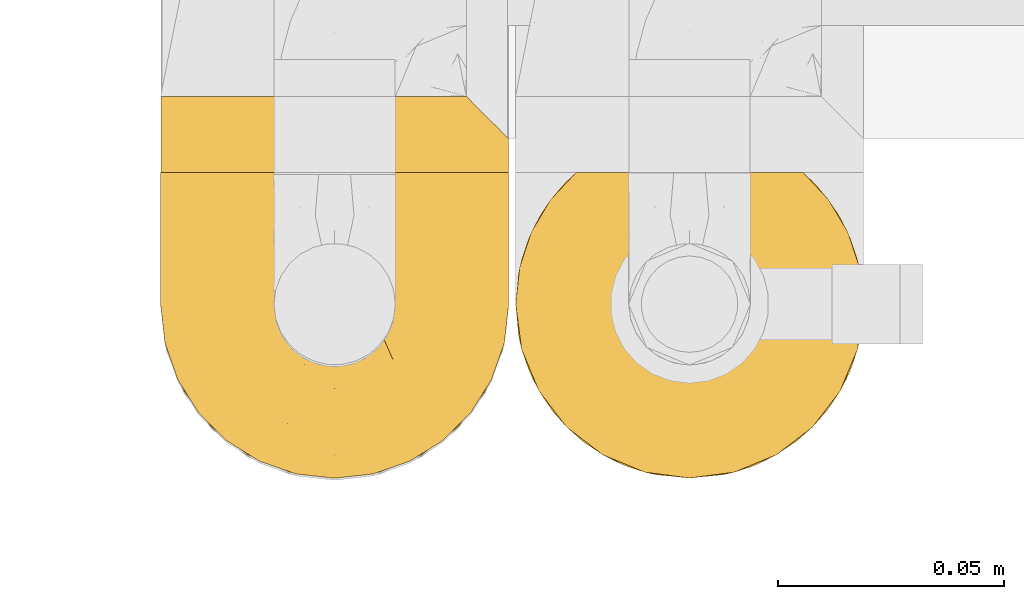
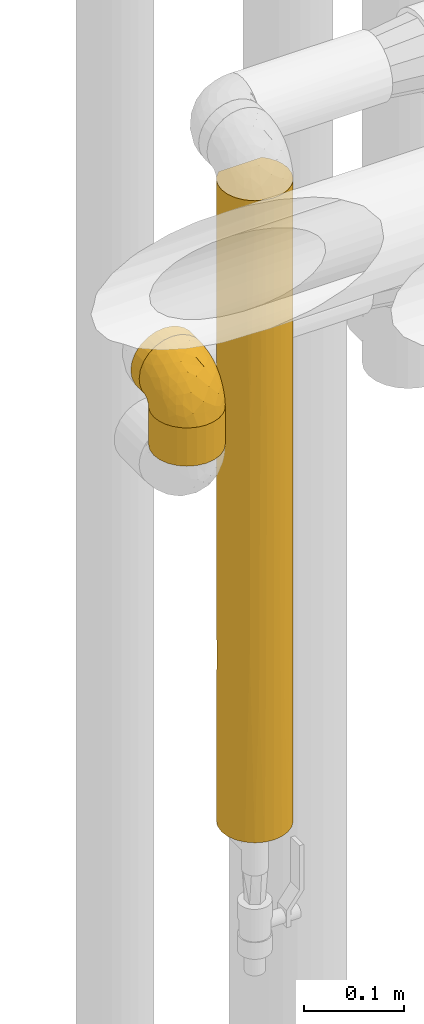
# One storey, part 465 of 827: 4 coverings.
"""IFC2X3 building model written with IfcOpenShell, lengths in millimetres."""

from ifc_helpers import new_model, entity, si_unit, converted_unit, derived_unit, direction, frame, origin, place, context, subcontext, project, spatial, faceted_brep, element, save


model = new_model("IFC2X3")

# Units and contexts
model_context = context("Model", 3, precision=0.01, world=origin(), true_north=direction((6.12303176911189e-17, 1.0)))
body_context = subcontext(model_context, "Body", "Model", "MODEL_VIEW")
ifc_project = project(units=[si_unit("LENGTHUNIT", "METRE", prefix="MILLI"), si_unit("AREAUNIT", "SQUARE_METRE"), si_unit("VOLUMEUNIT", "CUBIC_METRE"), converted_unit("PLANEANGLEUNIT", "DEGREE", entity("IfcRatioMeasure", 0.0174532925199433), si_unit("PLANEANGLEUNIT", "RADIAN"), dimensions=[0, 0, 0, 0, 0, 0, 0]), si_unit("MASSUNIT", "GRAM", prefix="KILO"), derived_unit("MASSDENSITYUNIT", [(si_unit("MASSUNIT", "GRAM", prefix="KILO"), 1), (si_unit("LENGTHUNIT", "METRE"), -3)]), derived_unit("MOMENTOFINERTIAUNIT", [(si_unit("LENGTHUNIT", "METRE"), 4)]), si_unit("TIMEUNIT", "SECOND"), si_unit("FREQUENCYUNIT", "HERTZ"), si_unit("THERMODYNAMICTEMPERATUREUNIT", "DEGREE_CELSIUS"), derived_unit("THERMALTRANSMITTANCEUNIT", [(si_unit("MASSUNIT", "GRAM", prefix="KILO"), 1), (si_unit("THERMODYNAMICTEMPERATUREUNIT", "KELVIN"), -1), (si_unit("TIMEUNIT", "SECOND"), -3)]), derived_unit("VOLUMETRICFLOWRATEUNIT", [(si_unit("LENGTHUNIT", "METRE"), 3), (si_unit("TIMEUNIT", "SECOND"), -1)]), derived_unit("MASSFLOWRATEUNIT", [(si_unit("MASSUNIT", "GRAM", prefix="KILO"), 1), (si_unit("TIMEUNIT", "SECOND"), -1)]), derived_unit("ROTATIONALFREQUENCYUNIT", [(si_unit("TIMEUNIT", "SECOND"), -1)]), si_unit("ELECTRICCURRENTUNIT", "AMPERE"), si_unit("ELECTRICVOLTAGEUNIT", "VOLT"), si_unit("POWERUNIT", "WATT"), si_unit("FORCEUNIT", "NEWTON", prefix="KILO"), si_unit("ILLUMINANCEUNIT", "LUX"), si_unit("LUMINOUSFLUXUNIT", "LUMEN"), si_unit("LUMINOUSINTENSITYUNIT", "CANDELA"), derived_unit("USERDEFINED", [(si_unit("MASSUNIT", "GRAM", prefix="KILO"), -1), (si_unit("LENGTHUNIT", "METRE"), -2), (si_unit("TIMEUNIT", "SECOND"), 3), (si_unit("LUMINOUSFLUXUNIT", "LUMEN"), 1)]), derived_unit("LINEARVELOCITYUNIT", [(si_unit("LENGTHUNIT", "METRE"), 1), (si_unit("TIMEUNIT", "SECOND"), -1)]), si_unit("PRESSUREUNIT", "PASCAL"), derived_unit("USERDEFINED", [(si_unit("LENGTHUNIT", "METRE"), -2), (si_unit("MASSUNIT", "GRAM", prefix="KILO"), 1), (si_unit("TIMEUNIT", "SECOND"), -2)]), derived_unit("LINEARFORCEUNIT", [(si_unit("MASSUNIT", "GRAM", prefix="KILO"), 1), (si_unit("LENGTHUNIT", "METRE"), 1), (si_unit("TIMEUNIT", "SECOND"), -2), (si_unit("LENGTHUNIT", "METRE"), -1)]), derived_unit("PLANARFORCEUNIT", [(si_unit("MASSUNIT", "GRAM", prefix="KILO"), 1), (si_unit("LENGTHUNIT", "METRE"), 1), (si_unit("TIMEUNIT", "SECOND"), -2), (si_unit("LENGTHUNIT", "METRE"), -2)])], contexts=[model_context])

# Site, building, storey
site_placement = place(None, origin())
site = spatial("IfcSite", under=ifc_project, at=site_placement, CompositionType="ELEMENT")
building_placement = place(site_placement, origin())
building = spatial("IfcBuilding", under=site, at=building_placement, CompositionType="ELEMENT")
storey_placement = place(building_placement, frame((0.0, 0.0, 28200.0)))
storey = spatial("IfcBuildingStorey", under=building, at=storey_placement, Name="08", CompositionType="ELEMENT", Elevation=28200.0)

# Coverings
covering_1_placement = place(storey_placement, frame((58529.6, 16264.84, 1836.7)))
element("IfcCovering", 1, at=covering_1_placement, inside=storey, Name=":ADSK_", ObjectType=":ADSK_", PredefinedType="INSULATION", context=body_context, shape_type="Brep", body=[
    faceted_brep([(73.25, 20.8, 784.2), (77.09, 30.06, 784.2), (78.4, 40.0, 784.2), (77.51, 48.2, 784.2), (74.9, 56.01, 784.2), (70.68, 63.08, 784.2), (65.05, 69.1, 784.2), (14.94, 69.1, 784.2), (9.31, 63.08, 784.2), (5.09, 56.01, 784.2), (2.48, 48.2, 784.2), (1.6, 40.0, 784.2), (2.9, 30.06, 784.2), (6.74, 20.8, 784.2), (12.84, 12.84, 784.2), (20.8, 6.74, 784.2), (30.06, 2.9, 784.2), (40.0, 1.6, 784.2), (49.93, 2.9, 784.2), (59.2, 6.74, 784.2), (67.15, 12.84, 784.2), (73.25, 20.8, 0.0), (67.15, 12.84, 0.0), (59.2, 6.74, 0.0), (49.93, 2.9, 0.0), (40.0, 1.6, 0.0), (30.06, 2.9, 0.0), (20.8, 6.74, 0.0), (12.84, 12.84, 0.0), (6.74, 20.8, 0.0), (2.9, 30.06, 0.0), (1.6, 40.0, 0.0), (2.9, 49.93, 0.0), (6.74, 59.2, 0.0), (12.84, 67.15, 0.0), (20.8, 73.25, 0.0), (30.06, 77.09, 0.0), (40.0, 78.4, 0.0), (49.93, 77.09, 0.0), (59.2, 73.25, 0.0), (67.15, 67.15, 0.0), (73.25, 59.2, 0.0), (77.09, 49.93, 0.0), (78.4, 40.0, 0.0), (77.09, 30.06, 0.0), (63.37, 9.53, 276.32), (55.3, 4.78, 607.88), (48.47, 2.54, 545.32), (53.31, 3.98, 185.06), (54.69, 4.52, 392.1), (47.49, 2.33, 304.24), (40.0, 1.6, 216.37), (70.46, 16.62, 233.29), (40.0, 1.6, 392.1), (40.0, 1.6, 567.83), (63.37, 9.53, 550.92), (75.47, 25.3, 392.1), (77.66, 32.5, 479.96), (76.01, 26.68, 599.14), (77.45, 31.52, 238.88), (75.21, 24.69, 176.32), (70.46, 16.62, 507.88), (78.4, 40.0, 392.1), (78.4, 40.0, 567.83), (78.4, 40.0, 216.37), (78.4, 40.0, 351.45), (68.42, 65.82, 310.48), (75.47, 54.69, 206.37), (77.08, 49.96, 459.64), (72.98, 59.66, 400.96), (62.59, 71.04, 388.61), (68.03, 66.24, 548.91), (77.79, 46.8, 218.92), (62.47, 71.13, 597.69), (64.09, 69.9, 180.01), (54.48, 75.56, 231.84), (40.0, 78.4, 558.53), (46.78, 77.79, 775.5), (50.2, 77.01, 468.31), (53.36, 76.0, 777.3), (40.0, 78.4, 342.15), (46.73, 77.8, 213.7), (59.51, 73.07, 780.23), (40.0, 78.4, 774.9), (57.05, 74.4, 489.42), (25.51, 75.56, 231.84), (22.94, 74.4, 489.42), (29.79, 77.01, 468.31), (17.52, 71.13, 597.69), (20.48, 73.07, 780.23), (33.26, 77.8, 213.7), (1.6, 40.0, 351.45), (1.6, 40.0, 567.83), (2.91, 49.96, 459.64), (7.01, 59.66, 400.96), (11.57, 65.82, 310.48), (4.52, 54.69, 206.37), (26.63, 76.0, 777.3), (33.21, 77.79, 775.5), (17.4, 71.04, 388.61), (15.9, 69.9, 180.01), (2.2, 46.8, 218.92), (11.96, 66.24, 548.91), (4.52, 25.3, 233.29), (16.62, 9.53, 233.29), (24.69, 4.78, 176.32), (2.26, 32.87, 459.64), (2.21, 33.14, 223.6), (9.53, 16.62, 614.91), (4.52, 25.3, 507.88), (9.53, 16.62, 169.29), (9.53, 16.62, 392.1), (25.3, 4.52, 392.1), (16.62, 9.53, 507.88), (31.52, 2.54, 238.88), (26.68, 3.98, 599.14), (32.5, 2.33, 479.96)], [[[0, 1, 2, 3, 4, 5, 6, 7, 8, 9, 10, 11, 12, 13, 14, 15, 16, 17, 18, 19, 20]], [[21, 22, 23, 24, 25, 26, 27, 28, 29, 30, 31, 32, 33, 34, 35, 36, 37, 38, 39, 40, 41, 42, 43, 44]], [[23, 22, 45]], [[46, 18, 47]], [[48, 49, 50]], [[51, 24, 50]], [[22, 21, 52]], [[53, 50, 47]], [[47, 50, 49]], [[17, 54, 53, 47]], [[45, 55, 49]], [[19, 55, 20]], [[49, 48, 45]], [[56, 57, 58]], [[44, 59, 60]], [[52, 21, 60]], [[61, 55, 45]], [[62, 57, 59]], [[56, 58, 61]], [[52, 56, 61]], [[45, 22, 52]], [[20, 61, 0]], [[2, 1, 63]], [[55, 61, 20]], [[55, 19, 46]], [[1, 58, 57]], [[45, 52, 61]], [[59, 57, 56]], [[50, 53, 51]], [[51, 25, 24]], [[48, 50, 24]], [[49, 46, 47]], [[17, 47, 18]], [[24, 23, 48]], [[45, 48, 23]], [[55, 46, 49]], [[18, 46, 19]], [[1, 57, 63]], [[62, 63, 57]], [[43, 64, 65, 62, 59]], [[56, 60, 59]], [[43, 59, 44]], [[1, 0, 58]], [[61, 58, 0]], [[52, 60, 56]], [[44, 60, 21]], [[66, 67, 41]], [[68, 69, 4]], [[68, 4, 3]], [[63, 68, 3]], [[3, 2, 63]], [[70, 71, 66]], [[67, 42, 41]], [[72, 43, 42]], [[41, 40, 66]], [[67, 72, 42]], [[69, 5, 4]], [[68, 63, 62, 65]], [[73, 71, 70]], [[70, 74, 75]], [[71, 6, 5]], [[71, 73, 6]], [[5, 69, 71]], [[76, 77, 78]], [[66, 71, 69]], [[77, 79, 78]], [[80, 81, 37]], [[6, 73, 82]], [[77, 76, 83]], [[84, 79, 82]], [[75, 81, 78]], [[74, 70, 66]], [[81, 75, 38]], [[84, 75, 78]], [[84, 73, 70]], [[84, 82, 73]], [[79, 84, 78]], [[70, 75, 84]], [[39, 38, 75]], [[66, 69, 67]], [[74, 66, 40]], [[40, 39, 74]], [[75, 74, 39]], [[69, 68, 67]], [[72, 68, 65]], [[68, 72, 67]], [[72, 65, 64, 43]], [[37, 81, 38]], [[78, 81, 80]], [[78, 80, 76]], [[85, 86, 87]], [[86, 88, 89]], [[90, 37, 36]], [[91, 92, 93]], [[94, 95, 96]], [[97, 98, 87]], [[85, 99, 86]], [[96, 95, 33]], [[97, 87, 86]], [[34, 95, 100]], [[98, 76, 87]], [[88, 7, 89]], [[9, 8, 94]], [[101, 93, 96]], [[102, 88, 99]], [[31, 91, 101]], [[94, 8, 102]], [[89, 97, 86]], [[85, 90, 36]], [[86, 99, 88]], [[94, 102, 95]], [[96, 33, 32]], [[11, 10, 92]], [[10, 9, 93]], [[102, 8, 7]], [[95, 102, 99]], [[88, 102, 7]], [[93, 9, 94]], [[10, 93, 92]], [[90, 87, 80]], [[36, 35, 85]], [[85, 35, 100]], [[100, 95, 99]], [[33, 95, 34]], [[85, 100, 99]], [[35, 34, 100]], [[101, 96, 32]], [[93, 94, 96]], [[31, 101, 32]], [[93, 101, 91]], [[87, 90, 85]], [[37, 90, 80]], [[76, 98, 83]], [[76, 80, 87]], [[30, 29, 103]], [[104, 27, 105]], [[106, 91, 107]], [[108, 109, 103, 110, 111]], [[107, 31, 30]], [[28, 110, 29]], [[91, 106, 92]], [[108, 14, 13]], [[13, 12, 109]], [[112, 113, 104]], [[111, 110, 104, 113, 108]], [[26, 114, 105]], [[115, 113, 112]], [[53, 116, 114]], [[108, 113, 14]], [[27, 104, 28]], [[12, 92, 106]], [[15, 14, 113]], [[17, 16, 54]], [[112, 116, 115]], [[106, 107, 103]], [[114, 116, 112]], [[103, 29, 110]], [[16, 115, 116]], [[12, 11, 92]], [[103, 109, 106]], [[12, 106, 109]], [[31, 107, 91]], [[30, 103, 107]], [[16, 116, 54]], [[53, 54, 116]], [[25, 51, 53, 114]], [[112, 105, 114]], [[25, 114, 26]], [[16, 15, 115]], [[113, 115, 15]], [[104, 105, 112]], [[26, 105, 27]], [[109, 108, 13]], [[104, 110, 28]], [[82, 79, 77, 83, 98, 97, 89, 7, 6]]]),
])
covering_2_placement = place(storey_placement, frame((58451.2, 16332.34, 2360.0)))
element("IfcCovering", 2, at=covering_2_placement, inside=storey, Name=":ADSK_", ObjectType=":ADSK_", PredefinedType="INSULATION", context=body_context, shape_type="Brep", body=[
    faceted_brep([(12.84, 18.4, 67.15), (20.8, 18.4, 73.25), (30.06, 18.4, 77.09), (40.0, 18.4, 78.4), (48.2, 18.4, 77.51), (56.01, 18.4, 74.9), (63.08, 18.4, 70.68), (69.1, 18.4, 65.05), (69.1, 18.4, 14.94), (63.08, 18.4, 9.31), (56.01, 18.4, 5.09), (48.2, 18.4, 2.48), (40.0, 18.4, 1.6), (30.06, 18.4, 2.9), (20.8, 18.4, 6.74), (12.84, 18.4, 12.84), (6.74, 18.4, 20.8), (2.9, 18.4, 30.06), (1.6, 18.4, 40.0), (2.9, 18.4, 49.93), (6.74, 18.4, 59.2), (30.06, 1.6, 77.09), (20.8, 1.6, 73.25), (12.84, 1.6, 67.15), (6.74, 1.6, 59.2), (2.9, 1.6, 49.93), (1.6, 1.6, 40.0), (2.48, 1.6, 31.79), (5.09, 1.6, 23.98), (9.31, 1.6, 16.91), (14.94, 1.6, 10.9), (65.05, 1.6, 10.9), (70.68, 1.6, 16.91), (74.9, 1.6, 23.98), (77.51, 1.6, 31.79), (78.4, 1.6, 40.0), (77.09, 1.6, 49.93), (73.25, 1.6, 59.2), (67.15, 1.6, 67.15), (59.2, 1.6, 73.25), (49.93, 1.6, 77.09), (40.0, 1.6, 78.4), (77.79, 9.7, 33.21), (76.0, 11.5, 26.63), (73.07, 14.42, 20.48), (78.4, 9.1, 40.0), (59.51, 5.57, 6.92), (53.36, 8.5, 4.0), (46.78, 10.29, 2.2), (40.0, 10.9, 1.6), (33.21, 10.29, 2.2), (26.63, 8.5, 4.0), (20.48, 5.57, 6.92), (76.0, 11.5, 53.36), (77.79, 9.7, 46.78), (73.07, 14.42, 59.51)], [[[0, 1, 2, 3, 4, 5, 6, 7, 8, 9, 10, 11, 12, 13, 14, 15, 16, 17, 18, 19, 20]], [[21, 22, 23, 24, 25, 26, 27, 28, 29, 30, 31, 32, 33, 34, 35, 36, 37, 38, 39, 40, 41]], [[42, 35, 34]], [[34, 33, 43]], [[32, 44, 33]], [[42, 45, 35]], [[44, 43, 33]], [[8, 44, 32]], [[42, 34, 43]], [[32, 31, 8]], [[31, 46, 9]], [[47, 48, 11]], [[46, 47, 10]], [[9, 46, 10]], [[48, 12, 11]], [[11, 10, 47]], [[12, 48, 49]], [[31, 9, 8]], [[50, 51, 13]], [[14, 52, 15]], [[51, 52, 14]], [[49, 50, 12]], [[12, 50, 13]], [[51, 14, 13]], [[52, 30, 15]], [[16, 29, 28]], [[28, 27, 17]], [[26, 18, 27]], [[15, 29, 16]], [[17, 16, 28]], [[18, 17, 27]], [[29, 15, 30]], [[18, 26, 25, 19]], [[19, 25, 24, 20]], [[20, 24, 23, 0]], [[1, 22, 21, 2]], [[2, 21, 41, 3]], [[0, 23, 22, 1]], [[4, 41, 40]], [[40, 39, 5]], [[38, 6, 39]], [[3, 41, 4]], [[5, 4, 40]], [[6, 5, 39]], [[38, 7, 6]], [[53, 37, 36]], [[36, 35, 54]], [[45, 54, 35]], [[7, 38, 55]], [[54, 53, 36]], [[55, 37, 53]], [[55, 38, 37]], [[7, 55, 53, 54, 45, 42, 43, 44, 8]], [[52, 51, 50, 49, 48, 47, 46, 31, 30]]]),
])
covering_3_placement = place(storey_placement, frame((58451.2, 16264.84, 2324.1)))
element("IfcCovering", 3, at=covering_3_placement, inside=storey, Name=":ADSK_", ObjectType=":ADSK_", PredefinedType="INSULATION", context=body_context, shape_type="Brep", body=[
    faceted_brep([(73.25, 20.8, 46.8), (77.09, 30.06, 46.8), (78.4, 40.0, 46.8), (77.51, 48.2, 46.8), (74.9, 56.01, 46.8), (70.68, 63.08, 46.8), (65.05, 69.1, 46.8), (14.94, 69.1, 46.8), (9.31, 63.08, 46.8), (5.09, 56.01, 46.8), (2.48, 48.2, 46.8), (1.6, 40.0, 46.8), (2.9, 30.06, 46.8), (6.74, 20.8, 46.8), (12.84, 12.84, 46.8), (20.8, 6.74, 46.8), (30.06, 2.9, 46.8), (40.0, 1.6, 46.8), (49.93, 2.9, 46.8), (59.2, 6.74, 46.8), (67.15, 12.84, 46.8), (73.25, 20.8, 0.0), (67.15, 12.84, 0.0), (59.2, 6.74, 0.0), (49.93, 2.9, 0.0), (40.0, 1.6, 0.0), (30.06, 2.9, 0.0), (20.8, 6.74, 0.0), (12.84, 12.84, 0.0), (6.74, 20.8, 0.0), (2.9, 30.06, 0.0), (1.6, 40.0, 0.0), (2.9, 49.93, 0.0), (6.74, 59.2, 0.0), (12.84, 67.15, 0.0), (20.8, 73.25, 0.0), (30.06, 77.09, 0.0), (40.0, 78.4, 0.0), (49.93, 77.09, 0.0), (59.2, 73.25, 0.0), (67.15, 67.15, 0.0), (73.25, 59.2, 0.0), (77.09, 49.93, 0.0), (78.4, 40.0, 0.0), (77.09, 30.06, 0.0), (53.36, 76.0, 39.9), (46.78, 77.79, 38.1), (40.0, 78.4, 37.5), (59.51, 73.07, 42.83), (33.21, 77.79, 38.1), (26.63, 76.0, 39.9), (20.48, 73.07, 42.83)], [[[0, 1, 2, 3, 4, 5, 6, 7, 8, 9, 10, 11, 12, 13, 14, 15, 16, 17, 18, 19, 20]], [[21, 22, 23, 24, 25, 26, 27, 28, 29, 30, 31, 32, 33, 34, 35, 36, 37, 38, 39, 40, 41, 42, 43, 44]], [[17, 25, 24, 18]], [[18, 24, 23, 19]], [[22, 20, 19, 23]], [[1, 0, 21, 44]], [[2, 1, 44, 43]], [[22, 21, 0, 20]], [[43, 42, 3]], [[41, 40, 5]], [[42, 41, 4]], [[3, 2, 43]], [[5, 4, 41]], [[3, 42, 4]], [[40, 6, 5]], [[45, 39, 38]], [[38, 37, 46]], [[47, 46, 37]], [[48, 6, 39]], [[46, 45, 38]], [[48, 39, 45]], [[39, 6, 40]], [[49, 47, 37]], [[49, 37, 36]], [[50, 36, 35]], [[50, 49, 36]], [[7, 51, 35]], [[50, 35, 51]], [[35, 34, 7]], [[8, 34, 33]], [[9, 33, 32]], [[10, 32, 31]], [[8, 33, 9]], [[9, 32, 10]], [[31, 11, 10]], [[34, 8, 7]], [[12, 11, 31, 30]], [[13, 12, 30, 29]], [[29, 28, 14, 13]], [[16, 15, 27, 26]], [[17, 16, 26, 25]], [[28, 27, 15, 14]], [[48, 45, 46, 47, 49, 50, 51, 7, 6]]]),
])
covering_4_placement = place(storey_placement, frame((58451.15, 16264.79, 2369.3)))
element("IfcCovering", 4, at=covering_4_placement, inside=storey, Name=":ADSK_", ObjectType=":ADSK_", PredefinedType="INSULATION", context=body_context, shape_type="Brep", body=[
    faceted_brep([(74.68, 23.36, 1.6), (70.1, 16.07, 1.6), (64.01, 9.98, 1.6), (56.72, 5.4, 1.6), (48.6, 2.56, 1.6), (40.05, 1.6, 1.6), (31.49, 2.56, 1.6), (23.36, 5.41, 1.6), (16.07, 9.99, 1.6), (9.98, 16.08, 1.6), (5.4, 23.37, 1.6), (2.56, 31.49, 1.6), (1.6, 40.05, 1.6), (2.46, 48.15, 1.6), (5.01, 55.88, 1.6), (9.13, 62.9, 1.6), (14.62, 68.89, 1.6), (16.82, 68.89, 1.6), (18.56, 68.89, 1.6), (20.52, 68.89, 1.6), (22.49, 68.89, 1.6), (24.46, 68.89, 1.6), (26.42, 68.89, 1.6), (28.39, 68.89, 1.6), (30.36, 68.89, 1.6), (32.55, 68.89, 1.6), (34.75, 68.89, 1.6), (36.94, 68.89, 1.6), (39.13, 68.89, 1.6), (41.33, 68.89, 1.6), (43.52, 68.89, 1.6), (45.72, 68.89, 1.6), (47.91, 68.89, 1.6), (50.11, 68.89, 1.6), (52.3, 68.89, 1.6), (54.49, 68.89, 1.6), (56.69, 68.89, 1.6), (58.88, 68.89, 1.6), (61.08, 68.89, 1.6), (63.27, 68.89, 1.6), (65.47, 68.89, 1.6), (70.97, 62.89, 1.6), (75.09, 55.86, 1.6), (77.64, 48.13, 1.6), (78.5, 40.05, 1.6), (77.53, 31.49, 1.6), (14.62, 69.15, 1.85), (9.12, 69.15, 7.85), (5.0, 69.15, 14.87), (2.46, 69.15, 22.6), (1.6, 69.15, 30.7), (2.91, 69.15, 40.65), (6.75, 69.15, 49.92), (12.86, 69.15, 57.88), (20.82, 69.15, 63.99), (30.09, 69.15, 67.84), (40.05, 69.15, 69.15), (50.0, 69.15, 67.84), (59.27, 69.15, 63.99), (67.23, 69.15, 57.88), (73.34, 69.15, 49.92), (77.19, 69.15, 40.65), (78.5, 69.15, 30.7), (77.63, 69.15, 22.6), (75.09, 69.15, 14.87), (70.97, 69.15, 7.85), (65.47, 69.15, 1.85), (63.27, 69.15, 1.85), (62.29, 69.15, 1.85), (60.7, 69.15, 1.85), (59.11, 69.15, 1.85), (57.52, 69.15, 1.85), (55.93, 69.15, 1.85), (54.34, 69.15, 1.85), (52.76, 69.15, 1.85), (51.17, 69.15, 1.85), (49.58, 69.15, 1.85), (47.99, 69.15, 1.85), (46.4, 69.15, 1.85), (44.81, 69.15, 1.85), (43.22, 69.15, 1.85), (41.63, 69.15, 1.85), (40.05, 69.15, 1.85), (38.46, 69.15, 1.85), (36.87, 69.15, 1.85), (35.28, 69.15, 1.85), (33.69, 69.15, 1.85), (32.1, 69.15, 1.85), (30.51, 69.15, 1.85), (28.92, 69.15, 1.85), (27.33, 69.15, 1.85), (25.37, 69.15, 1.85), (23.4, 69.15, 1.85), (21.21, 69.15, 1.85), (19.01, 69.15, 1.85), (16.82, 69.15, 1.85), (42.32, 68.96, 1.77), (44.02, 68.97, 1.78), (47.13, 68.97, 1.77), (48.74, 68.97, 1.77), (23.57, 68.95, 1.76), (25.13, 68.96, 1.77), (61.34, 68.98, 1.79), (22.02, 68.97, 1.78), (29.72, 68.97, 1.78), (56.73, 68.98, 1.78), (55.14, 68.97, 1.78), (37.66, 68.97, 1.78), (64.12, 68.94, 1.74), (28.13, 68.98, 1.78), (26.62, 68.98, 1.78), (31.46, 68.96, 1.77), (16.16, 68.97, 1.78), (39.16, 68.98, 1.78), (50.37, 68.98, 1.78), (17.69, 68.97, 1.77), (19.17, 68.96, 1.77), (62.78, 68.97, 1.77), (58.35, 68.97, 1.78), (45.53, 68.98, 1.78), (59.91, 68.96, 1.77), (65.47, 68.97, 1.77), (65.47, 68.94, 1.72), (65.47, 68.92, 1.66), (14.62, 68.97, 1.77), (14.62, 69.02, 1.8), (14.62, 69.08, 1.82), (20.59, 68.98, 1.79), (32.99, 68.97, 1.78), (34.48, 68.98, 1.79), (51.91, 68.97, 1.78), (65.47, 69.08, 1.82), (65.47, 69.02, 1.8), (53.48, 68.96, 1.76), (14.62, 68.92, 1.66), (14.62, 68.94, 1.72), (40.77, 68.97, 1.78), (35.97, 68.96, 1.77), (7.84, 67.02, 9.41), (3.53, 63.33, 17.65), (8.32, 64.61, 7.41), (1.6, 49.27, 21.47), (2.19, 51.4, 15.21), (1.6, 43.94, 16.15), (1.6, 61.87, 28.75), (4.57, 61.54, 13.67), (3.96, 57.95, 12.79), (2.28, 56.12, 19.18), (1.6, 63.4, 29.16), (7.69, 65.41, 9.04), (3.53, 53.1, 7.41), (8.32, 63.04, 5.74), (7.84, 61.33, 3.72), (1.6, 41.99, 8.87), (1.6, 54.6, 26.8), (4.34, 56.6, 9.53), (1.6, 41.58, 7.34), (29.63, 13.72, 37.63), (27.34, 5.82, 17.92), (40.05, 6.74, 27.45), (2.39, 58.82, 37.01), (2.43, 51.58, 34.22), (9.07, 42.09, 45.87), (16.64, 46.12, 56.57), (9.54, 55.56, 52.31), (4.52, 52.38, 42.07), (4.52, 61.54, 44.74), (7.49, 23.76, 21.49), (7.49, 20.5, 11.02), (12.85, 14.64, 15.64), (2.35, 41.77, 26.02), (22.66, 16.28, 36.59), (32.9, 49.4, 65.49), (25.33, 52.34, 63.99), (40.05, 4.3, 15.2), (16.64, 58.67, 60.27), (19.99, 25.26, 45.25), (16.37, 20.17, 35.21), (3.26, 34.7, 22.52), (3.75, 28.67, 12.03), (19.58, 8.62, 13.32), (7.5, 33.37, 35.9), (4.04, 41.35, 33.87), (13.94, 17.15, 25.73), (19.58, 12.68, 26.34), (28.21, 21.47, 46.78), (24.75, 41.11, 59.54), (31.42, 37.53, 60.18), (26.2, 30.64, 53.93), (33.36, 26.66, 53.36), (40.05, 21.38, 49.36), (40.05, 14.06, 38.4), (40.05, 55.54, 66.44), (16.14, 35.17, 50.09), (12.85, 29.04, 41.08), (10.47, 24.34, 31.14), (6.49, 29.33, 28.19), (40.05, 43.3, 64.0), (40.05, 32.34, 56.68), (75.57, 57.75, 43.9), (47.37, 49.41, 65.46), (52.91, 27.85, 52.22), (50.46, 13.7, 37.61), (67.23, 14.63, 15.64), (60.5, 8.61, 13.31), (70.55, 48.85, 50.02), (63.45, 54.13, 59.28), (62.61, 37.84, 53.05), (72.6, 23.75, 21.48), (72.6, 20.49, 11.01), (76.34, 28.66, 12.03), (59.34, 20.83, 41.02), (77.76, 55.15, 35.39), (78.5, 54.6, 26.8), (78.5, 61.87, 28.75), (78.5, 41.58, 7.34), (53.16, 57.58, 65.81), (70.55, 59.91, 53.28), (48.88, 36.94, 59.8), (54.76, 45.72, 61.82), (52.74, 5.82, 17.91), (71.93, 37.91, 41.4), (75.79, 50.18, 40.48), (60.5, 12.67, 26.34), (77.86, 49.29, 31.68), (77.64, 42.64, 27.68), (78.5, 43.94, 16.15), (78.5, 49.27, 21.47), (67.23, 19.45, 28.05), (76.82, 34.7, 22.54), (78.5, 41.99, 8.87), (77.8, 62.29, 37.3), (67.23, 29.01, 41.07), (73.2, 31.47, 32.24), (67.66, 37.18, 47.4), (75.99, 43.45, 35.77), (76.57, 63.33, 17.65), (73.21, 67.23, 11.06), (71.93, 66.07, 8.55), (71.07, 65.22, 6.63), (75.09, 61.99, 12.77), (76.13, 57.95, 12.79), (76.57, 53.09, 7.41), (77.69, 56.84, 18.97), (72.26, 61.33, 3.72), (71.77, 63.06, 5.76), (77.9, 51.41, 15.21), (75.75, 56.61, 9.52)], [[[0, 1, 2, 3, 4, 5, 6, 7, 8, 9, 10, 11, 12, 13, 14, 15, 16, 17, 18, 19, 20, 21, 22, 23, 24, 25, 26, 27, 28, 29, 30, 31, 32, 33, 34, 35, 36, 37, 38, 39, 40, 41, 42, 43, 44, 45]], [[46, 47, 48, 49, 50, 51, 52, 53, 54, 55, 56, 57, 58, 59, 60, 61, 62, 63, 64, 65, 66, 67, 68, 69, 70, 71, 72, 73, 74, 75, 76, 77, 78, 79, 80, 81, 82, 83, 84, 85, 86, 87, 88, 89, 90, 91, 92, 93, 94, 95]], [[96, 97, 30]], [[98, 77, 99]], [[100, 101, 21]], [[69, 68, 102]], [[20, 19, 103]], [[24, 23, 104]], [[20, 103, 100]], [[72, 105, 106]], [[84, 83, 107]], [[89, 88, 104]], [[108, 67, 66]], [[109, 110, 90]], [[111, 25, 24]], [[112, 17, 16]], [[82, 113, 83]], [[109, 23, 22]], [[114, 76, 75]], [[105, 36, 106]], [[104, 111, 24]], [[18, 115, 116]], [[97, 96, 80]], [[67, 108, 117]], [[105, 71, 118]], [[31, 97, 119]], [[102, 120, 69]], [[108, 121, 122, 123, 40]], [[112, 95, 115]], [[17, 115, 18]], [[94, 116, 115]], [[117, 68, 67]], [[38, 117, 39]], [[112, 124, 125, 126, 46]], [[17, 112, 115]], [[70, 120, 118]], [[39, 117, 108]], [[120, 38, 37]], [[120, 37, 118]], [[120, 70, 69]], [[116, 94, 127]], [[128, 86, 129]], [[117, 38, 102]], [[74, 130, 75]], [[99, 33, 32]], [[115, 95, 94]], [[39, 108, 40]], [[108, 66, 131, 132, 121]], [[105, 72, 71]], [[118, 37, 36]], [[71, 70, 118]], [[35, 106, 36]], [[36, 105, 118]], [[35, 133, 106]], [[74, 73, 133]], [[106, 133, 73]], [[99, 114, 33]], [[133, 35, 34]], [[73, 72, 106]], [[95, 112, 46]], [[112, 16, 134, 135, 124]], [[130, 114, 75]], [[99, 76, 114]], [[114, 130, 33]], [[34, 33, 130]], [[78, 77, 98]], [[98, 119, 78]], [[130, 133, 34]], [[133, 130, 74]], [[79, 97, 80]], [[98, 99, 32]], [[98, 32, 31]], [[77, 76, 99]], [[97, 79, 119]], [[136, 96, 29]], [[30, 97, 31]], [[136, 29, 28]], [[81, 80, 96]], [[29, 96, 30]], [[31, 119, 98]], [[119, 79, 78]], [[96, 136, 81]], [[82, 81, 136]], [[113, 107, 83]], [[84, 107, 137]], [[107, 27, 137]], [[113, 28, 107]], [[27, 107, 28]], [[85, 84, 137]], [[137, 27, 26]], [[113, 136, 28]], [[136, 113, 82]], [[109, 89, 104]], [[86, 85, 129]], [[89, 109, 90]], [[111, 87, 128]], [[26, 129, 137]], [[88, 111, 104]], [[25, 111, 128]], [[22, 110, 109]], [[23, 109, 104]], [[110, 91, 90]], [[100, 92, 101]], [[110, 22, 101]], [[91, 110, 101]], [[116, 19, 18]], [[111, 88, 87]], [[127, 103, 19]], [[25, 128, 26]], [[86, 128, 87]], [[128, 129, 26]], [[137, 129, 85]], [[120, 102, 38]], [[117, 102, 68]], [[91, 101, 92]], [[21, 101, 22]], [[93, 92, 103]], [[100, 21, 20]], [[100, 103, 92]], [[127, 93, 103]], [[93, 127, 94]], [[116, 127, 19]], [[126, 138, 47]], [[48, 138, 139]], [[140, 125, 124]], [[141, 142, 143]], [[144, 49, 139]], [[145, 140, 146]], [[48, 139, 49]], [[139, 145, 147]], [[49, 144, 148, 50]], [[126, 125, 149]], [[14, 13, 150]], [[151, 146, 140]], [[149, 140, 145]], [[152, 151, 135]], [[152, 14, 150]], [[16, 15, 134]], [[13, 153, 150]], [[124, 151, 140]], [[141, 147, 142]], [[14, 152, 15]], [[15, 152, 134]], [[47, 46, 126]], [[139, 154, 144]], [[138, 48, 47]], [[125, 140, 149]], [[135, 134, 152]], [[146, 155, 142]], [[145, 146, 147]], [[149, 139, 138]], [[147, 141, 154]], [[147, 146, 142]], [[139, 147, 154]], [[139, 149, 145]], [[149, 138, 126]], [[155, 146, 151]], [[150, 143, 142]], [[152, 155, 151]], [[150, 142, 155]], [[13, 12, 156, 153]], [[153, 143, 150]], [[152, 150, 155]], [[151, 124, 135]], [[157, 158, 159]], [[160, 154, 161]], [[162, 163, 164]], [[165, 166, 160]], [[167, 168, 169]], [[141, 170, 161]], [[156, 12, 11]], [[158, 157, 171]], [[172, 55, 173]], [[158, 6, 174]], [[175, 54, 53]], [[52, 166, 164]], [[52, 164, 53]], [[54, 175, 173]], [[166, 52, 51]], [[176, 177, 171]], [[178, 143, 179]], [[156, 11, 179]], [[8, 7, 180]], [[169, 9, 8]], [[179, 143, 153, 156]], [[179, 11, 10]], [[168, 179, 10]], [[181, 162, 182]], [[179, 167, 178]], [[183, 184, 177]], [[183, 169, 184]], [[176, 171, 185]], [[172, 186, 187]], [[158, 7, 6]], [[159, 158, 174]], [[184, 180, 158]], [[54, 173, 55]], [[180, 169, 8]], [[188, 189, 187]], [[9, 168, 10]], [[186, 188, 187]], [[190, 157, 159, 191]], [[55, 172, 192]], [[176, 193, 194]], [[161, 170, 182]], [[162, 164, 165]], [[175, 164, 163]], [[51, 50, 148]], [[167, 195, 196]], [[178, 182, 170]], [[6, 5, 174]], [[158, 180, 7]], [[169, 180, 184]], [[169, 168, 9]], [[179, 168, 167]], [[182, 162, 165]], [[162, 194, 193]], [[161, 165, 160]], [[195, 181, 196]], [[192, 172, 197]], [[192, 56, 55]], [[189, 190, 198]], [[198, 197, 187]], [[172, 187, 197]], [[185, 189, 188]], [[198, 187, 189]], [[186, 172, 173]], [[173, 163, 186]], [[193, 186, 163]], [[176, 185, 188]], [[185, 157, 190]], [[188, 186, 193]], [[177, 176, 194]], [[188, 193, 176]], [[162, 193, 163]], [[195, 177, 194]], [[171, 177, 184]], [[181, 195, 194]], [[183, 167, 169]], [[162, 181, 194]], [[196, 182, 178]], [[158, 171, 184]], [[171, 157, 185]], [[177, 195, 183]], [[167, 183, 195]], [[182, 196, 181]], [[178, 170, 143]], [[178, 167, 196]], [[164, 175, 53]], [[173, 175, 163]], [[160, 51, 148]], [[164, 166, 165]], [[51, 160, 166]], [[160, 148, 144, 154]], [[141, 161, 154]], [[182, 165, 161]], [[190, 189, 185]], [[143, 170, 141]], [[60, 199, 61]], [[197, 200, 192]], [[201, 190, 202]], [[200, 57, 192]], [[203, 204, 2]], [[205, 206, 207]], [[208, 209, 210]], [[211, 207, 201]], [[212, 213, 214]], [[45, 215, 210]], [[216, 206, 58]], [[45, 44, 215]], [[59, 217, 60]], [[60, 217, 199]], [[0, 45, 210]], [[218, 201, 219]], [[202, 159, 220]], [[205, 221, 222]], [[223, 204, 203]], [[1, 203, 2]], [[57, 200, 216]], [[220, 3, 204]], [[220, 174, 4]], [[1, 0, 209]], [[212, 224, 213]], [[225, 226, 227]], [[228, 223, 203]], [[208, 210, 229]], [[210, 226, 229]], [[3, 220, 4]], [[58, 206, 59]], [[209, 203, 1]], [[202, 220, 223]], [[228, 203, 208]], [[202, 211, 201]], [[3, 2, 204]], [[202, 190, 191, 159]], [[210, 215, 230, 226]], [[199, 212, 231]], [[232, 233, 221]], [[233, 208, 229]], [[207, 206, 219]], [[217, 206, 205]], [[227, 224, 225]], [[233, 232, 228]], [[201, 207, 219]], [[234, 232, 221]], [[218, 219, 200]], [[202, 223, 211]], [[174, 220, 159]], [[174, 5, 4]], [[61, 231, 62]], [[220, 204, 223]], [[210, 209, 0]], [[203, 209, 208]], [[225, 233, 229]], [[224, 227, 213]], [[221, 233, 235]], [[57, 56, 192]], [[198, 218, 197]], [[200, 219, 216]], [[201, 198, 190]], [[197, 218, 200]], [[198, 201, 218]], [[206, 216, 219]], [[58, 57, 216]], [[231, 212, 214]], [[222, 212, 199]], [[228, 211, 223]], [[207, 211, 232]], [[62, 231, 214]], [[199, 231, 61]], [[233, 228, 208]], [[211, 228, 232]], [[222, 221, 235]], [[234, 205, 207]], [[206, 217, 59]], [[199, 217, 205]], [[205, 222, 199]], [[224, 222, 235]], [[222, 224, 212]], [[224, 235, 225]], [[233, 225, 235]], [[226, 225, 229]], [[205, 234, 221]], [[207, 232, 234]], [[63, 214, 236]], [[214, 213, 236]], [[214, 63, 62]], [[237, 236, 238]], [[238, 132, 131]], [[236, 237, 64]], [[239, 240, 241]], [[63, 236, 64]], [[131, 66, 65]], [[237, 131, 65]], [[242, 230, 43]], [[237, 65, 64]], [[239, 121, 132]], [[42, 242, 43]], [[241, 240, 243]], [[41, 123, 244]], [[43, 230, 215, 44]], [[244, 122, 245]], [[227, 246, 243]], [[241, 247, 245]], [[121, 239, 245]], [[41, 40, 123]], [[132, 238, 239]], [[244, 42, 41]], [[131, 237, 238]], [[240, 239, 238]], [[245, 239, 241]], [[247, 241, 246]], [[247, 244, 245]], [[238, 236, 240]], [[243, 236, 213]], [[236, 243, 240]], [[227, 226, 246]], [[243, 213, 227]], [[242, 246, 226]], [[243, 246, 241]], [[246, 242, 247]], [[244, 247, 242]], [[242, 226, 230]], [[42, 244, 242]], [[122, 244, 123]], [[122, 121, 245]]]),
])

save(model, "model.ifc")
